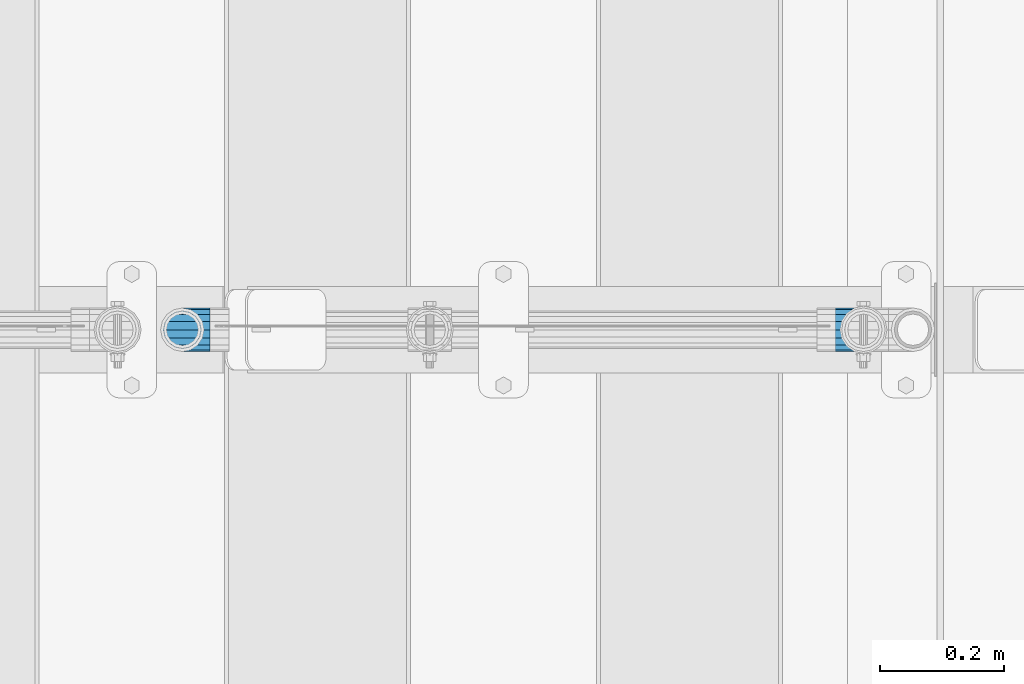
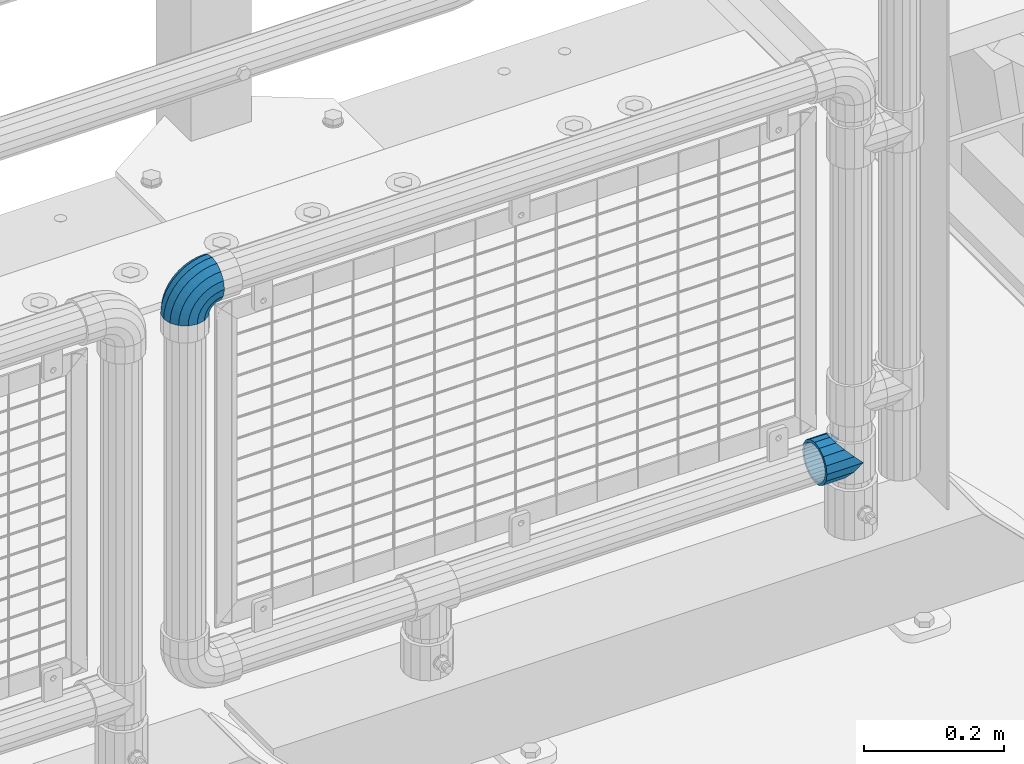
# One storey, part 128 of 193: 1 beam, 1 member.
"""IFC2X3 building model written with IfcOpenShell, lengths in millimetres."""

from ifc_helpers import new_model, si_unit, frame, origin_with_axes, place, context, subcontext, project, spatial, faceted_brep, material, type_object, element, save


model = new_model("IFC2X3")

# Units and contexts
model_context = context("Model", 3, precision=1e-05, world=origin_with_axes())
body_context = subcontext(model_context, "Body", "Model", "MODEL_VIEW")
ifc_project = project(units=[si_unit("LENGTHUNIT", "METRE", prefix="MILLI"), si_unit("AREAUNIT", "SQUARE_METRE"), si_unit("VOLUMEUNIT", "CUBIC_METRE"), si_unit("MASSUNIT", "GRAM", prefix="KILO"), si_unit("TIMEUNIT", "SECOND"), si_unit("PLANEANGLEUNIT", "RADIAN"), si_unit("SOLIDANGLEUNIT", "STERADIAN"), si_unit("THERMODYNAMICTEMPERATUREUNIT", "DEGREE_CELSIUS"), si_unit("LUMINOUSINTENSITYUNIT", "LUMEN")], contexts=[model_context])

# Site, building, storey
site_placement = place(None, origin_with_axes())
site = spatial("IfcSite", under=ifc_project, at=site_placement, CompositionType="ELEMENT")
building_placement = place(site_placement, origin_with_axes())
building = spatial("IfcBuilding", under=site, at=building_placement, Name="Standard", CompositionType="ELEMENT")
storey_placement = place(building_placement, origin_with_axes())
storey = spatial("IfcBuildingStorey", under=building, at=storey_placement, Name="Undefined", CompositionType="ELEMENT", Elevation=0.0)

# Beam
ifc_material = material(Name="Misc_Undefined")
beam_type = type_object("IfcBeamType", PredefinedType="NOTDEFINED")
beam_placement = place(storey_placement, frame((-29019.0, 28664.5, 298.670000000001), z_axis=(0.0, 1.0, 0.0), x_axis=(-1.0, 0.0, 0.0)))
element("IfcBeam", 1, at=beam_placement, inside=storey, type_object=beam_type, material=ifc_material, context=body_context, shape_type="Brep", body=[
    faceted_brep([(0.0, 0.0, -35.1500000000015), (13.4513226476338, -13.4513226476329, -32.4743655677703), (13.4513226476338, 13.4513226476329, -32.4743655677703), (27.1226768591041, -21.4606908090117, 21.46069080901), (32.4743655677703, -26.8123795176776, 13.4513226476338), (32.4743655677703, -32.4743655677717, 13.4513226476338), (24.8548033587067, -24.8548033587072, 24.8548033587067), (24.8548033587067, -16.3810424080013, 24.8548033587067), (32.8397438117208, -28.0397438117175, 11.614442172282), (35.1500000000015, -30.35, 0.0), (35.1500000000015, -35.15, 0.0), (32.4743655677703, -26.8123795176754, -13.4513226476338), (32.4743655677703, -32.4743655677717, -13.4513226476338), (32.8397438117172, -28.0397438117175, -11.614442172282), (24.8548033587067, -16.3810424080013, -24.8548033587067), (24.8548033587067, -24.8548033587072, -24.8548033587067), (27.1226768591114, -21.4606908090117, -21.46069080901), (20.0882031229849, -11.6144421722805, -28.0397438117179), (16.6306603983721, 0.0, -30.3499999999985), (20.0882031229849, 11.6144421722805, -28.0397438117179), (24.8548033587067, 16.3810424080013, -24.8548033587067), (24.8548033587067, 24.8548033587072, -24.8548033587067), (27.1226768591114, 21.4606908090117, -21.46069080901), (32.4743655677703, 26.8123795176776, -13.4513226476338), (32.4743655677703, 32.4743655677717, -13.4513226476338), (32.8397438117172, 28.0397438117175, -11.614442172282), (35.1500000000015, 30.35, 0.0), (35.1500000000015, 35.15, 0.0), (32.8397438117208, 28.0397438117175, 11.614442172282), (32.4743655677703, 26.8123795176754, 13.4513226476338), (32.4743655677703, 32.4743655677717, 13.4513226476338), (27.1226768591041, 21.4606908090117, 21.46069080901), (24.8548033587067, 16.3810424080078, 24.8548033587067), (24.8548033587067, 24.8548033587072, 24.8548033587067), (0.0, 0.0, 35.1500000000015), (13.4513226476338, 13.4513226476329, 32.4743655677703), (13.4513226476338, -13.4513226476329, 32.4743655677703), (20.0882031229849, 11.6144421722805, 28.0397438117179), (16.6306603983685, 0.0, 30.3499999999985), (20.0882031229849, -11.6144421722805, 28.0397438117179), (60.1500000000015, -35.15, 0.0), (60.1500000000015, -32.4743655677717, 13.4513226476338), (60.1500000000015, -24.8548033587072, 24.8548033587067), (60.1500000000015, -13.4513226476329, 32.4743655677703), (60.1500000000015, 0.0, 35.1500000000015), (60.1500000000015, -24.8548033587072, -24.8548033587067), (60.1500000000015, -32.4743655677717, -13.4513226476338), (60.1500000000015, -13.4513226476329, -32.4743655677703), (60.1500000000015, 0.0, -35.1500000000015), (60.1500000000015, 13.4513226476329, -32.4743655677703), (60.1500000000015, 24.8548033587072, -24.8548033587067), (60.1500000000015, 32.4743655677717, -13.4513226476338), (60.1500000000015, 35.15, 0.0), (60.1500000000015, 32.4743655677717, 13.4513226476338), (60.1500000000015, 24.8548033587072, 24.8548033587067), (60.1500000000015, 13.4513226476329, 32.4743655677703), (60.1500000000015, -21.4606908090117, 21.46069080901), (60.1500000000015, -11.6144421722805, 28.0397438117179), (60.1500000000015, 0.0, 30.3499999999985), (60.1500000000015, 11.6144421722805, 28.0397438117179), (60.1500000000015, 21.4606908090117, 21.46069080901), (60.1500000000015, 28.0397438117175, 11.614442172282), (60.1500000000015, 30.35, 0.0), (60.1500000000015, 28.0397438117175, -11.614442172282), (60.1500000000015, 21.4606908090117, -21.46069080901), (60.1500000000015, 11.6144421722805, -28.0397438117179), (60.1500000000015, 0.0, -30.3499999999985), (60.1500000000015, -11.6144421722805, -28.0397438117179), (60.1500000000015, -21.4606908090117, -21.46069080901), (60.1500000000015, -28.0397438117175, -11.614442172282), (60.1500000000015, -30.35, 0.0), (60.1500000000015, -28.0397438117175, 11.614442172282)], [[[0, 1, 2]], [[3, 4, 5, 6, 7]], [[8, 9, 10, 5, 4]], [[11, 12, 10, 9, 13]], [[14, 15, 12, 11, 16]], [[2, 1, 15, 14, 17, 18, 19, 20, 21]], [[21, 20, 22, 23, 24]], [[24, 23, 25, 26, 27]], [[27, 26, 28, 29, 30]], [[30, 29, 31, 32, 33]], [[34, 35, 36]], [[33, 32, 37, 38, 39, 7, 6, 36, 35]], [[40, 41, 5, 10]], [[41, 42, 6, 5]], [[42, 43, 36, 6]], [[43, 44, 34, 36]], [[45, 46, 12, 15]], [[47, 45, 15, 1]], [[48, 47, 1, 0]], [[49, 48, 0, 2]], [[50, 49, 2, 21]], [[51, 50, 21, 24]], [[52, 51, 24, 27]], [[53, 52, 27, 30]], [[54, 53, 30, 33]], [[55, 54, 33, 35]], [[44, 55, 35, 34]], [[46, 40, 10, 12]], [[45, 47, 48, 49, 50, 51, 52, 53, 54, 55, 44, 43, 42, 41, 40, 46], [56, 57, 58, 59, 60, 61, 62, 63, 64, 65, 66, 67, 68, 69, 70, 71]], [[59, 58, 38, 37]], [[31, 60, 59, 37, 32]], [[28, 61, 60, 31, 29]], [[62, 61, 28, 26]], [[63, 62, 26, 25]], [[64, 63, 25, 23, 22]], [[65, 64, 22, 20, 19]], [[66, 65, 19, 18]], [[67, 66, 18, 17]], [[16, 68, 67, 17, 14]], [[13, 69, 68, 16, 11]], [[70, 69, 13, 9]], [[71, 70, 9, 8]], [[56, 71, 8, 4, 3]], [[57, 56, 3, 7, 39]], [[58, 57, 39, 38]]]),
])

# Member
member_type = type_object("IfcMemberType", PredefinedType="NOTDEFINED")
member_placement = place(storey_placement, frame((-30118.39, 28664.5, 924.849999999999), z_axis=(-0.707106781186548, 0.0, 0.707106781186548), x_axis=(0.707106781186547, 0.0, 0.707106781186548)))
element("IfcMember", 2, at=member_placement, inside=storey, type_object=member_type, material=ifc_material, context=body_context, shape_type="Brep", body=[
    faceted_brep([(0.0, -35.1500000000015, 0.0), (9.51152146007007, -32.4743655677703, -9.51152146007007), (13.2759578763398, -32.4743655677703, -6.2963890252795), (5.36946880023243, -35.1500000000015, 4.58595959347804), (17.5749999999971, -24.8548033587067, -17.5750000000007), (19.978755663109, -24.8548033587067, -15.5219987155651), (22.9628441077002, -13.4513226476338, -22.9628441077002), (24.4574219585229, -13.4513226476338, -21.6863540323939), (24.8548033587067, 0.0, -24.8548033587067), (26.0301204183124, 0.0, -23.850987758804), (22.9628441077002, 13.4513226476338, -22.9628441077002), (24.4574219585229, 13.4513226476338, -21.6863540323939), (17.5749999999971, 24.8548033587067, -17.5750000000007), (19.978755663109, 24.8548033587067, -15.5219987155651), (9.51152146007007, 32.4743655677703, -9.51152146007007), (13.2759578763398, 32.4743655677703, -6.2963890252795), (0.0, 35.1500000000015, 0.0), (5.36946880023243, 35.1500000000015, 4.58595959347804), (-9.51152146007007, 32.4743655677703, 9.51152146007007), (-2.53702027587133, 32.4743655677703, 15.4683082122356), (-17.5750000000007, 24.8548033587067, 17.5750000000007), (-9.23981806264419, 24.8548033587067, 24.6939179025212), (-22.9628441077039, 13.4513226476338, 22.9628441077002), (-13.718484358058, 13.4513226476338, 30.8582732193499), (-24.8548033587103, 0.0, 24.8548033587067), (-15.2911828178476, 0.0, 33.02290694576), (-22.9628441077039, -13.4513226476338, 22.9628441077002), (-13.718484358058, -13.4513226476338, 30.8582732193499), (-17.5750000000007, -24.8548033587067, 17.5750000000007), (-9.23981806264419, -24.8548033587067, 24.6939179025212), (-9.51152146007007, -32.4743655677703, 9.51152146007007), (-2.53702027587133, -32.4743655677703, 15.4683082122356), (0.0, -30.3499999999985, 0.0), (-8.2126508197216, -28.0397438117179, 8.21265081971796), (-1.45732902223972, -28.0397438117179, 13.9822406910389), (5.36946880023243, -30.3499999999985, 4.58595959347804), (-15.1749999999993, -21.46069080901, 15.1749999999993), (-7.24480876131565, -21.46069080901, 21.9480231689959), (-19.827092992, -11.614442172282, 19.827092992), (-11.1118790903529, -11.614442172282, 27.2705888550809), (-21.4606908090136, 0.0, 21.46069080901), (-12.4698136068437, 0.0, 29.139625372758), (-19.827092992, 11.614442172282, 19.827092992), (-11.1118790903529, 11.614442172282, 27.2705888550809), (-15.1749999999993, 21.46069080901, 15.1749999999993), (-7.24480876131565, 21.46069080901, 21.9480231689959), (-8.2126508197216, 28.0397438117179, 8.21265081971796), (-1.45732902223972, 28.0397438117179, 13.9822406910389), (0.0, 30.3499999999985, 0.0), (5.36946880023243, 30.3499999999985, 4.58595959347804), (8.21265081971796, 28.0397438117179, -8.2126508197216), (12.1962666227009, 28.0397438117179, -4.81032150408282), (15.1749999999956, 21.46069080901, -15.1749999999993), (17.9837463617769, 21.46069080901, -12.7761039820398), (19.8270929919963, 11.614442172282, -19.827092992), (21.8508166908177, 11.614442172282, -18.0986696681211), (21.46069080901, 0.0, -21.46069080901), (23.2087512073085, 0.0, -19.9677061858019), (19.8270929919963, -11.614442172282, -19.827092992), (21.8508166908177, -11.614442172282, -18.0986696681211), (15.1749999999956, -21.46069080901, -15.1749999999993), (17.9837463617769, -21.46069080901, -12.7761039820398), (8.21265081971796, -28.0397438117179, -8.2126508197216), (12.1962666227009, -28.0397438117179, -4.81032150408282), (17.4970053560683, -32.4743655677703, -3.70972780292141), (11.3902326651114, -35.1500000000015, 8.27548843508339), (22.6740772628618, -24.8548033587067, -13.8703035149447), (26.1332861179508, -13.4513226476338, -20.6593831546779), (27.3479987309584, 0.0, -23.0433908901396), (26.1332861179508, 13.4513226476338, -20.6593831546779), (22.6740772628618, 24.8548033587067, -13.8703035149447), (17.4970053560683, 32.4743655677703, -3.70972780292141), (11.3902326651114, 35.1500000000015, 8.27548843508339), (5.28345997415818, 32.4743655677703, 20.2607046730882), (0.106388067368243, 24.8548033587067, 30.4212803851115), (-3.35282078772434, 13.4513226476338, 37.2103600248483), (-4.56753340073192, 0.0, 39.5943677603027), (-3.35282078772434, -13.4513226476338, 37.2103600248483), (0.106388067368243, -24.8548033587067, 30.4212803851115), (5.28345997415818, -32.4743655677703, 20.2607046730882), (6.11738625912403, -28.0397438117179, 18.6240321853948), (11.3902326651114, -30.3499999999985, 8.27548843508339), (1.6472829199738, -21.46069080901, 27.3971039594981), (-1.3395446405375, -11.614442172282, 33.259083107896), (-2.38837900198268, 0.0, 35.3175364441995), (-1.3395446405375, 11.614442172282, 33.259083107896), (1.6472829199738, 21.46069080901, 27.3971039594981), (6.11738625912403, 28.0397438117179, 18.6240321853948), (11.3902326651114, 30.3499999999985, 8.27548843508339), (16.6630790711024, 28.0397438117179, -2.07305531522434), (21.1331824102526, 21.46069080901, -10.8461270893349), (24.1200099707639, 11.614442172282, -16.7081062377292), (25.1688443322091, 0.0, -18.7665595740327), (24.1200099707639, -11.614442172282, -16.7081062377292), (21.1331824102526, -21.46069080901, -10.8461270893349), (16.6630790711024, -28.0397438117179, -2.07305531522434), (22.070727701459, -32.4743655677703, -1.81522997693173), (17.9140404065183, -35.1500000000015, 10.9777380798878), (25.5945970362081, -24.8548033587067, -12.6605846156453), (27.9491712485069, -13.4513226476338, -19.9072189058934), (28.7759877587996, 0.0, -22.4518984678871), (27.9491712485069, 13.4513226476338, -19.9072189058934), (25.5945970362081, 24.8548033587067, -12.6605846156453), (22.070727701459, 32.4743655677703, -1.81522997693173), (17.9140404065183, 35.1500000000015, 10.9777380798878), (13.7573531115813, 32.4743655677703, 23.7707061367037), (10.2334837768358, 24.8548033587067, 34.6160607754209), (7.87890956453339, 13.4513226476338, 41.8626950656653), (7.05209305424069, 0.0, 44.407374627659), (7.87890956453339, -13.4513226476338, 41.8626950656653), (10.2334837768358, -24.8548033587067, 34.6160607754209), (13.7573531115813, -32.4743655677703, 23.7707061367037), (14.3249803951003, -28.0397438117179, 22.0237289909674), (17.9140404065183, -30.3499999999985, 10.9777380798878), (11.2823222355109, -21.46069080901, 31.3880679179965), (9.24928305077992, -11.614442172282, 37.6451191472661), (8.53537462723762, 0.0, 39.8423033494473), (9.24928305077992, 11.614442172282, 37.6451191472661), (11.2823222355109, 21.46069080901, 31.3880679179965), (14.3249803951003, 28.0397438117179, 22.0237289909674), (17.9140404065183, 30.3499999999985, 10.9777380798878), (21.50310041794, 28.0397438117179, -0.0682528311917849), (24.545758577533, 21.46069080901, -9.43259175821731), (26.5787977622604, 11.614442172282, -15.6896429874942), (27.2927061858027, 0.0, -17.8868271896717), (26.5787977622604, -11.614442172282, -15.6896429874942), (24.545758577533, -21.46069080901, -9.43259175821731), (21.50310041794, -28.0397438117179, -0.0682528311917849), (26.8845046890456, -32.4743655677703, -0.659544371261291), (24.7802542265854, -35.1500000000015, 12.6261701733893), (28.6684020936846, -24.8548033587067, -11.9226293117936), (29.8603642316994, -13.4513226476338, -19.4483820661262), (30.2789256727447, 0.0, -22.0910749985305), (29.8603642316994, 13.4513226476338, -19.4483820661262), (28.6684020936846, 24.8548033587067, -11.9226293117936), (26.8845046890456, 32.4743655677703, -0.659544371261291), (24.7802542265854, 35.1500000000015, 12.6261701733893), (22.6760037641179, 32.4743655677703, 25.9118847180362), (20.8921063594826, 24.8548033587067, 37.1749696585684), (19.7001442214678, 13.4513226476338, 44.7007224129011), (19.2815827804188, 0.0, 47.3434153453054), (19.7001442214678, -13.4513226476338, 44.7007224129011), (20.8921063594826, -24.8548033587067, 37.1749696585684), (22.6760037641179, -32.4743655677703, 25.9118847180362), (22.963355178621, -28.0397438117179, 24.0976192894668), (24.7802542265854, -30.3499999999985, 12.6261701733893), (21.4230625404816, -21.46069080901, 33.8226442665655), (20.3938719035323, -11.614442172282, 40.3206982094962), (20.032468212612, 0.0, 42.6025113104479), (20.3938719035323, 11.614442172282, 40.3206982094962), (21.4230625404816, 21.46069080901, 33.8226442665655), (22.963355178621, 28.0397438117179, 24.0976192894668), (24.7802542265854, 30.3499999999985, 12.6261701733893), (26.5971532745461, 28.0397438117179, 1.15472105730805), (28.1374459126819, 21.46069080901, -8.5703039197906), (29.1666365496349, 11.614442172282, -15.0683578627213), (29.5280402405551, 0.0, -17.3501709636766), (29.1666365496349, -11.614442172282, -15.0683578627213), (28.1374459126819, -21.46069080901, -8.5703039197906), (26.5971532745461, -28.0397438117179, 1.15472105730805), (31.8198051533946, -32.4743655677703, -0.271127801028342), (31.8198051533946, -35.1500000000015, 13.1801948466054), (31.8198051533946, -24.8548033587067, -11.6746085121013), (31.8198051533946, -13.4513226476338, -19.2941707211648), (31.8198051533909, 0.0, -21.969805153396), (31.8198051533946, 13.4513226476338, -19.2941707211648), (31.8198051533946, 24.8548033587067, -11.6746085121013), (31.8198051533946, 32.4743655677703, -0.271127801028342), (31.8198051533946, 35.1500000000015, 13.1801948466054), (31.8198051533946, 32.4743655677703, 26.6315174942392), (31.8198051533909, 24.8548033587067, 38.0349982053121), (31.8198051533946, 13.4513226476338, 45.6545604143794), (31.8198051533946, 0.0, 48.3301948466069), (31.8198051533946, -13.4513226476338, 45.6545604143794), (31.8198051533909, -24.8548033587067, 38.0349982053121), (31.8198051533946, -32.4743655677703, 26.6315174942392), (31.8198051533909, -28.0397438117179, 24.7946370188874), (31.8198051533946, -30.3499999999985, 13.1801948466054), (31.8198051533946, -21.46069080901, 34.6408856556154), (31.8198051533946, -11.614442172282, 41.219938658327), (31.8198051533909, 0.0, 43.530194846604), (31.8198051533946, 11.614442172282, 41.219938658327), (31.8198051533946, 21.46069080901, 34.6408856556154), (31.8198051533909, 28.0397438117179, 24.7946370188874), (31.8198051533946, 30.3499999999985, 13.1801948466054), (31.8198051533946, 28.0397438117179, 1.56575267432709), (31.8198051533909, 21.46069080901, -8.28049596240453), (31.8198051533946, 11.614442172282, -14.8595489651125), (31.8198051533909, 0.0, -17.1698051533931), (31.8198051533946, -11.614442172282, -14.8595489651125), (31.8198051533909, -21.46069080901, -8.28049596240453), (31.8198051533946, -28.0397438117179, 1.56575267432709), (36.7551056177363, -32.4743655677703, -0.659544371264928), (38.8593560802037, -35.1500000000015, 12.6261701733893), (34.9712082131009, -24.8548033587067, -11.9226293117936), (33.7792460750898, -13.4513226476338, -19.4483820661226), (33.3606846340372, 0.0, -22.0910749985305), (33.7792460750898, 13.4513226476338, -19.4483820661226), (34.9712082131009, 24.8548033587067, -11.9226293117936), (36.7551056177363, 32.4743655677703, -0.659544371264928), (38.8593560802037, 35.1500000000015, 12.6261701733893), (40.9636065426712, 32.4743655677703, 25.9118847180362), (42.7475039473065, 24.8548033587067, 37.1749696585684), (43.9394660853177, 13.4513226476338, 44.7007224128974), (44.3580275263666, 0.0, 47.343415345309), (43.9394660853177, -13.4513226476338, 44.7007224128974), (42.7475039473065, -24.8548033587067, 37.1749696585684), (40.9636065426712, -32.4743655677703, 25.9118847180362), (40.6762551281645, -28.0397438117179, 24.0976192894632), (38.8593560802037, -30.3499999999985, 12.6261701733893), (42.2165477663038, -21.46069080901, 33.8226442665655), (43.2457384032568, -11.614442172282, 40.3206982094962), (43.6071420941771, 0.0, 42.6025113104515), (43.2457384032568, 11.614442172282, 40.3206982094962), (42.2165477663038, 21.46069080901, 33.8226442665655), (40.6762551281645, 28.0397438117179, 24.0976192894632), (38.8593560802037, 30.3499999999985, 12.6261701733893), (37.042457032243, 28.0397438117179, 1.15472105730805), (35.5021643941, 21.46069080901, -8.5703039197906), (34.4729737571543, 11.614442172282, -15.0683578627213), (34.1115700662303, 0.0, -17.3501709636766), (34.4729737571543, -11.614442172282, -15.0683578627213), (35.5021643941, -21.46069080901, -8.5703039197906), (37.042457032243, -28.0397438117179, 1.15472105730805), (41.5688826053265, -32.4743655677703, -1.81522997693173), (45.7255699002671, -35.1500000000015, 10.9777380798878), (38.0450132705773, -24.8548033587067, -12.6605846156453), (35.6904390582786, -13.4513226476338, -19.9072189058897), (34.8636225479859, 0.0, -22.4518984678834), (35.6904390582786, 13.4513226476338, -19.9072189058897), (38.0450132705773, 24.8548033587067, -12.6605846156453), (41.5688826053265, 32.4743655677703, -1.81522997693173), (45.7255699002671, 35.1500000000015, 10.9777380798878), (49.8822571952041, 32.4743655677703, 23.7707061367073), (53.4061265299533, 24.8548033587067, 34.6160607754173), (55.7607007422557, 13.4513226476338, 41.862695065669), (56.5875172525448, 0.0, 44.4073746276626), (55.7607007422557, -13.4513226476338, 41.862695065669), (53.4061265299533, -24.8548033587067, 34.6160607754173), (49.8822571952041, -32.4743655677703, 23.7707061367073), (49.3146299116852, -28.0397438117179, 22.0237289909674), (45.7255699002671, -30.3499999999985, 10.9777380798878), (52.3572880712782, -21.46069080901, 31.3880679179929), (54.3903272560092, -11.614442172282, 37.6451191472697), (55.1042356795442, 0.0, 39.8423033494437), (54.3903272560092, 11.614442172282, 37.6451191472697), (52.3572880712782, 21.46069080901, 31.3880679179929), (49.3146299116852, 28.0397438117179, 22.0237289909674), (45.7255699002671, 30.3499999999985, 10.9777380798878), (42.1365098888455, 28.0397438117179, -0.0682528311954229), (39.0938517292525, 21.46069080901, -9.43259175821731), (37.0608125445215, 11.614442172282, -15.6896429874905), (36.3469041209864, 0.0, -17.8868271896681), (37.0608125445215, -11.614442172282, -15.6896429874905), (39.0938517292525, -21.46069080901, -9.43259175821731), (42.1365098888455, -28.0397438117179, -0.0682528311954229), (46.1426049507172, -32.4743655677703, -3.70972780292141), (52.2493776416704, -35.1500000000015, 8.27548843508339), (40.9655330439236, -24.8548033587067, -13.8703035149447), (37.5063241888347, -13.4513226476338, -20.6593831546816), (36.2916115758235, 0.0, -23.0433908901359), (37.5063241888347, 13.4513226476338, -20.6593831546816), (40.9655330439236, 24.8548033587067, -13.8703035149447), (46.1426049507172, 32.4743655677703, -3.70972780292141), (52.2493776416704, 35.1500000000015, 8.27548843508339), (58.3561503326309, 32.4743655677703, 20.2607046730882), (63.5332222394209, 24.8548033587067, 30.4212803851115), (66.9924310945134, 13.4513226476338, 37.2103600248447), (68.2071437075174, 0.0, 39.5943677603027), (66.9924310945134, -13.4513226476338, 37.2103600248447), (63.5332222394209, -24.8548033587067, 30.4212803851115), (58.3561503326309, -32.4743655677703, 20.2607046730882), (57.5222240476651, -28.0397438117179, 18.6240321853911), (52.2493776416704, -30.3499999999985, 8.27548843508339), (61.9923273868117, -21.46069080901, 27.3971039595017), (64.9791549473193, -11.614442172282, 33.259083107896), (66.0279893087682, 0.0, 35.3175364441995), (64.9791549473193, 11.614442172282, 33.259083107896), (61.9923273868117, 21.46069080901, 27.3971039595017), (57.5222240476651, 28.0397438117179, 18.6240321853911), (52.2493776416704, 30.3499999999985, 8.27548843508339), (46.9765312356831, 28.0397438117179, -2.07305531522798), (42.5064278965328, 21.46069080901, -10.8461270893386), (39.5196003360215, 11.614442172282, -16.7081062377292), (38.4707659745764, 0.0, -18.7665595740364), (39.5196003360215, -11.614442172282, -16.7081062377292), (42.5064278965328, -21.46069080901, -10.8461270893386), (46.9765312356831, -28.0397438117179, -2.07305531522798), (50.3636524304493, -32.4743655677703, -6.29638902527586), (58.2701415065567, -35.1500000000015, 4.58595959347804), (43.6608546436801, -24.8548033587067, -15.5219987155615), (39.1821883482626, -13.4513226476338, -21.6863540323939), (37.6094898884767, 0.0, -23.8509877588003), (39.1821883482626, 13.4513226476338, -21.6863540323939), (43.6608546436801, 24.8548033587067, -15.5219987155615), (50.3636524304493, 32.4743655677703, -6.29638902527586), (58.2701415065567, 35.1500000000015, 4.58595959347804), (66.1766305826604, 32.4743655677703, 15.4683082122319), (72.8794283694333, 24.8548033587067, 24.6939179025212), (77.3580946648435, 13.4513226476338, 30.8582732193499), (78.9307931246331, 0.0, 33.0229069457564), (77.3580946648435, -13.4513226476338, 30.8582732193499), (72.8794283694333, -24.8548033587067, 24.6939179025212), (66.1766305826604, -32.4743655677703, 15.4683082122319), (65.0969393290252, -28.0397438117179, 13.9822406910425), (58.2701415065567, -30.3499999999985, 4.58595959347804), (70.8844190680975, -21.46069080901, 21.9480231689959), (74.751489397142, -11.614442172282, 27.2705888550772), (76.1094239136291, 0.0, 29.1396253727617), (74.751489397142, 11.614442172282, 27.2705888550772), (70.8844190680975, 21.46069080901, 21.9480231689959), (65.0969393290252, 28.0397438117179, 13.9822406910425), (58.2701415065567, 30.3499999999985, 4.58595959347804), (51.4433436840845, 28.0397438117179, -4.81032150407918), (45.6558639450086, 21.46069080901, -12.7761039820361), (41.7887936159677, 11.614442172282, -18.0986696681211), (40.4308590994769, 0.0, -19.9677061857983), (41.7887936159677, -11.614442172282, -18.0986696681211), (45.6558639450086, -21.46069080901, -12.7761039820361), (51.4433436840845, -28.0397438117179, -4.81032150407918), (54.128088846719, -32.4743655677703, -9.51152146007007), (63.6396103067891, -35.1500000000015, 0.0), (46.0646103067884, -24.8548033587067, -17.5750000000007), (40.6767661990889, -13.4513226476338, -22.9628441077002), (38.7848069480824, 0.0, -24.8548033587067), (40.6767661990889, 13.4513226476338, -22.9628441077002), (46.0646103067884, 24.8548033587067, -17.5750000000007), (54.128088846719, 32.4743655677703, -9.51152146007007), (63.6396103067891, 35.1500000000015, 0.0), (73.1511317668592, 32.4743655677703, 9.51152146007007), (81.2146103067898, 24.8548033587067, 17.5750000000007), (86.602454414493, 13.4513226476338, 22.9628441077039), (88.4944136654958, 0.0, 24.8548033587067), (86.602454414493, -13.4513226476338, 22.9628441077039), (81.2146103067898, -24.8548033587067, 17.5750000000007), (73.1511317668592, -32.4743655677703, 9.51152146007007), (71.8522611265071, -28.0397438117179, 8.21265081971796), (63.6396103067891, -30.3499999999985, 0.0), (78.8146103067884, -21.46069080901, 15.1749999999993), (83.4667032987891, -11.614442172282, 19.827092992), (85.1003011158027, 0.0, 21.4606908090136), (83.4667032987891, 11.614442172282, 19.827092992), (78.8146103067884, 21.46069080901, 15.1749999999993), (71.8522611265071, 28.0397438117179, 8.21265081971796), (63.6396103067891, 30.3499999999985, 0.0), (55.4269594870711, 28.0397438117179, -8.21265081971796), (48.4646103067898, 21.46069080901, -15.1749999999993), (43.8125173147891, 11.614442172282, -19.8270929919963), (42.1789194977791, 0.0, -21.46069080901), (43.8125173147891, -11.614442172282, -19.8270929919963), (48.4646103067898, -21.46069080901, -15.1749999999993), (55.4269594870711, -28.0397438117179, -8.21265081971796)], [[[0, 1, 2, 3]], [[1, 4, 5, 2]], [[4, 6, 7, 5]], [[6, 8, 9, 7]], [[8, 10, 11, 9]], [[10, 12, 13, 11]], [[12, 14, 15, 13]], [[14, 16, 17, 15]], [[16, 18, 19, 17]], [[18, 20, 21, 19]], [[20, 22, 23, 21]], [[22, 24, 25, 23]], [[24, 26, 27, 25]], [[26, 28, 29, 27]], [[28, 30, 31, 29]], [[30, 0, 3, 31]], [[32, 33, 34, 35]], [[33, 36, 37, 34]], [[36, 38, 39, 37]], [[38, 40, 41, 39]], [[40, 42, 43, 41]], [[42, 44, 45, 43]], [[44, 46, 47, 45]], [[46, 48, 49, 47]], [[48, 50, 51, 49]], [[50, 52, 53, 51]], [[52, 54, 55, 53]], [[54, 56, 57, 55]], [[56, 58, 59, 57]], [[58, 60, 61, 59]], [[60, 62, 63, 61]], [[62, 32, 35, 63]], [[30, 28, 26, 24, 22, 20, 18, 16, 14, 12, 10, 8, 6, 4, 1, 0], [62, 60, 58, 56, 54, 52, 50, 48, 46, 44, 42, 40, 38, 36, 33, 32]], [[3, 2, 64, 65]], [[2, 5, 66, 64]], [[5, 7, 67, 66]], [[7, 9, 68, 67]], [[9, 11, 69, 68]], [[11, 13, 70, 69]], [[13, 15, 71, 70]], [[15, 17, 72, 71]], [[17, 19, 73, 72]], [[19, 21, 74, 73]], [[21, 23, 75, 74]], [[23, 25, 76, 75]], [[25, 27, 77, 76]], [[27, 29, 78, 77]], [[29, 31, 79, 78]], [[31, 3, 65, 79]], [[35, 34, 80, 81]], [[34, 37, 82, 80]], [[37, 39, 83, 82]], [[39, 41, 84, 83]], [[41, 43, 85, 84]], [[43, 45, 86, 85]], [[45, 47, 87, 86]], [[47, 49, 88, 87]], [[49, 51, 89, 88]], [[51, 53, 90, 89]], [[53, 55, 91, 90]], [[55, 57, 92, 91]], [[57, 59, 93, 92]], [[59, 61, 94, 93]], [[61, 63, 95, 94]], [[63, 35, 81, 95]], [[65, 64, 96, 97]], [[64, 66, 98, 96]], [[66, 67, 99, 98]], [[67, 68, 100, 99]], [[68, 69, 101, 100]], [[69, 70, 102, 101]], [[70, 71, 103, 102]], [[71, 72, 104, 103]], [[72, 73, 105, 104]], [[73, 74, 106, 105]], [[74, 75, 107, 106]], [[75, 76, 108, 107]], [[76, 77, 109, 108]], [[77, 78, 110, 109]], [[78, 79, 111, 110]], [[79, 65, 97, 111]], [[81, 80, 112, 113]], [[80, 82, 114, 112]], [[82, 83, 115, 114]], [[83, 84, 116, 115]], [[84, 85, 117, 116]], [[85, 86, 118, 117]], [[86, 87, 119, 118]], [[87, 88, 120, 119]], [[88, 89, 121, 120]], [[89, 90, 122, 121]], [[90, 91, 123, 122]], [[91, 92, 124, 123]], [[92, 93, 125, 124]], [[93, 94, 126, 125]], [[94, 95, 127, 126]], [[95, 81, 113, 127]], [[97, 96, 128, 129]], [[96, 98, 130, 128]], [[98, 99, 131, 130]], [[99, 100, 132, 131]], [[100, 101, 133, 132]], [[101, 102, 134, 133]], [[102, 103, 135, 134]], [[103, 104, 136, 135]], [[104, 105, 137, 136]], [[105, 106, 138, 137]], [[106, 107, 139, 138]], [[107, 108, 140, 139]], [[108, 109, 141, 140]], [[109, 110, 142, 141]], [[110, 111, 143, 142]], [[111, 97, 129, 143]], [[113, 112, 144, 145]], [[112, 114, 146, 144]], [[114, 115, 147, 146]], [[115, 116, 148, 147]], [[116, 117, 149, 148]], [[117, 118, 150, 149]], [[118, 119, 151, 150]], [[119, 120, 152, 151]], [[120, 121, 153, 152]], [[121, 122, 154, 153]], [[122, 123, 155, 154]], [[123, 124, 156, 155]], [[124, 125, 157, 156]], [[125, 126, 158, 157]], [[126, 127, 159, 158]], [[127, 113, 145, 159]], [[129, 128, 160, 161]], [[128, 130, 162, 160]], [[130, 131, 163, 162]], [[131, 132, 164, 163]], [[132, 133, 165, 164]], [[133, 134, 166, 165]], [[134, 135, 167, 166]], [[135, 136, 168, 167]], [[136, 137, 169, 168]], [[137, 138, 170, 169]], [[138, 139, 171, 170]], [[139, 140, 172, 171]], [[140, 141, 173, 172]], [[141, 142, 174, 173]], [[142, 143, 175, 174]], [[143, 129, 161, 175]], [[145, 144, 176, 177]], [[144, 146, 178, 176]], [[146, 147, 179, 178]], [[147, 148, 180, 179]], [[148, 149, 181, 180]], [[149, 150, 182, 181]], [[150, 151, 183, 182]], [[151, 152, 184, 183]], [[152, 153, 185, 184]], [[153, 154, 186, 185]], [[154, 155, 187, 186]], [[155, 156, 188, 187]], [[156, 157, 189, 188]], [[157, 158, 190, 189]], [[158, 159, 191, 190]], [[159, 145, 177, 191]], [[161, 160, 192, 193]], [[160, 162, 194, 192]], [[162, 163, 195, 194]], [[163, 164, 196, 195]], [[164, 165, 197, 196]], [[165, 166, 198, 197]], [[166, 167, 199, 198]], [[167, 168, 200, 199]], [[168, 169, 201, 200]], [[169, 170, 202, 201]], [[170, 171, 203, 202]], [[171, 172, 204, 203]], [[172, 173, 205, 204]], [[173, 174, 206, 205]], [[174, 175, 207, 206]], [[175, 161, 193, 207]], [[177, 176, 208, 209]], [[176, 178, 210, 208]], [[178, 179, 211, 210]], [[179, 180, 212, 211]], [[180, 181, 213, 212]], [[181, 182, 214, 213]], [[182, 183, 215, 214]], [[183, 184, 216, 215]], [[184, 185, 217, 216]], [[185, 186, 218, 217]], [[186, 187, 219, 218]], [[187, 188, 220, 219]], [[188, 189, 221, 220]], [[189, 190, 222, 221]], [[190, 191, 223, 222]], [[191, 177, 209, 223]], [[193, 192, 224, 225]], [[192, 194, 226, 224]], [[194, 195, 227, 226]], [[195, 196, 228, 227]], [[196, 197, 229, 228]], [[197, 198, 230, 229]], [[198, 199, 231, 230]], [[199, 200, 232, 231]], [[200, 201, 233, 232]], [[201, 202, 234, 233]], [[202, 203, 235, 234]], [[203, 204, 236, 235]], [[204, 205, 237, 236]], [[205, 206, 238, 237]], [[206, 207, 239, 238]], [[207, 193, 225, 239]], [[209, 208, 240, 241]], [[208, 210, 242, 240]], [[210, 211, 243, 242]], [[211, 212, 244, 243]], [[212, 213, 245, 244]], [[213, 214, 246, 245]], [[214, 215, 247, 246]], [[215, 216, 248, 247]], [[216, 217, 249, 248]], [[217, 218, 250, 249]], [[218, 219, 251, 250]], [[219, 220, 252, 251]], [[220, 221, 253, 252]], [[221, 222, 254, 253]], [[222, 223, 255, 254]], [[223, 209, 241, 255]], [[225, 224, 256, 257]], [[224, 226, 258, 256]], [[226, 227, 259, 258]], [[227, 228, 260, 259]], [[228, 229, 261, 260]], [[229, 230, 262, 261]], [[230, 231, 263, 262]], [[231, 232, 264, 263]], [[232, 233, 265, 264]], [[233, 234, 266, 265]], [[234, 235, 267, 266]], [[235, 236, 268, 267]], [[236, 237, 269, 268]], [[237, 238, 270, 269]], [[238, 239, 271, 270]], [[239, 225, 257, 271]], [[241, 240, 272, 273]], [[240, 242, 274, 272]], [[242, 243, 275, 274]], [[243, 244, 276, 275]], [[244, 245, 277, 276]], [[245, 246, 278, 277]], [[246, 247, 279, 278]], [[247, 248, 280, 279]], [[248, 249, 281, 280]], [[249, 250, 282, 281]], [[250, 251, 283, 282]], [[251, 252, 284, 283]], [[252, 253, 285, 284]], [[253, 254, 286, 285]], [[254, 255, 287, 286]], [[255, 241, 273, 287]], [[257, 256, 288, 289]], [[256, 258, 290, 288]], [[258, 259, 291, 290]], [[259, 260, 292, 291]], [[260, 261, 293, 292]], [[261, 262, 294, 293]], [[262, 263, 295, 294]], [[263, 264, 296, 295]], [[264, 265, 297, 296]], [[265, 266, 298, 297]], [[266, 267, 299, 298]], [[267, 268, 300, 299]], [[268, 269, 301, 300]], [[269, 270, 302, 301]], [[270, 271, 303, 302]], [[271, 257, 289, 303]], [[273, 272, 304, 305]], [[272, 274, 306, 304]], [[274, 275, 307, 306]], [[275, 276, 308, 307]], [[276, 277, 309, 308]], [[277, 278, 310, 309]], [[278, 279, 311, 310]], [[279, 280, 312, 311]], [[280, 281, 313, 312]], [[281, 282, 314, 313]], [[282, 283, 315, 314]], [[283, 284, 316, 315]], [[284, 285, 317, 316]], [[285, 286, 318, 317]], [[286, 287, 319, 318]], [[287, 273, 305, 319]], [[289, 288, 320, 321]], [[288, 290, 322, 320]], [[290, 291, 323, 322]], [[291, 292, 324, 323]], [[292, 293, 325, 324]], [[293, 294, 326, 325]], [[294, 295, 327, 326]], [[295, 296, 328, 327]], [[296, 297, 329, 328]], [[297, 298, 330, 329]], [[298, 299, 331, 330]], [[299, 300, 332, 331]], [[300, 301, 333, 332]], [[301, 302, 334, 333]], [[302, 303, 335, 334]], [[303, 289, 321, 335]], [[305, 304, 336, 337]], [[304, 306, 338, 336]], [[306, 307, 339, 338]], [[307, 308, 340, 339]], [[308, 309, 341, 340]], [[309, 310, 342, 341]], [[310, 311, 343, 342]], [[311, 312, 344, 343]], [[312, 313, 345, 344]], [[313, 314, 346, 345]], [[314, 315, 347, 346]], [[315, 316, 348, 347]], [[316, 317, 349, 348]], [[317, 318, 350, 349]], [[318, 319, 351, 350]], [[319, 305, 337, 351]], [[322, 323, 324, 325, 326, 327, 328, 329, 330, 331, 332, 333, 334, 335, 321, 320], [338, 339, 340, 341, 342, 343, 344, 345, 346, 347, 348, 349, 350, 351, 337, 336]]]),
])

save(model, "model.ifc")
